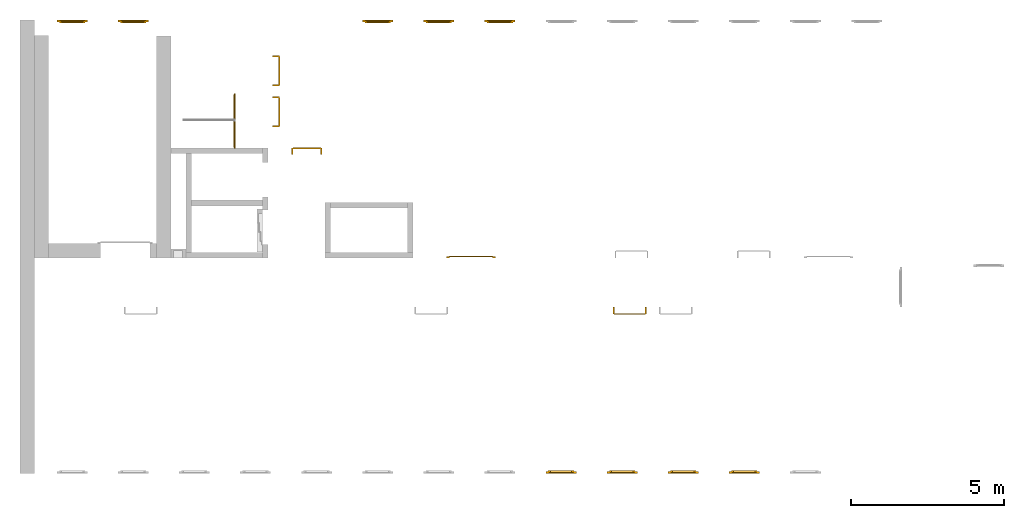
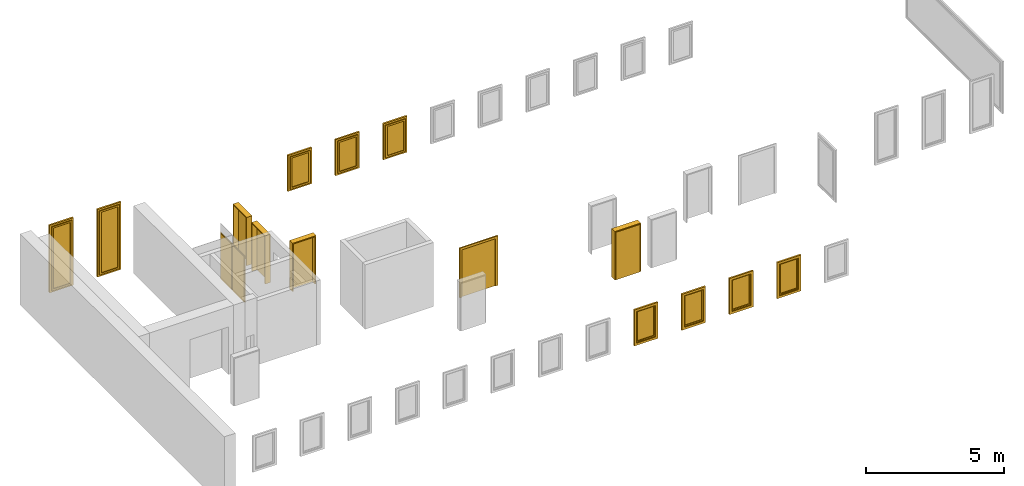
# One storey, part 3 of 5: 9 windows, 7 doors.
"""IFC4 building model written with IfcOpenShell, lengths in metres."""

from ifc_helpers import new_model, entity, si_unit, converted_unit, derived_unit, direction, frame, origin_with_axes, place, context, subcontext, project, spatial, polygons, source, transform, mapped, type_object, element, save


model = new_model("IFC4")

# Units and contexts
model_context = context("Model", 3, precision=1e-05, world=origin_with_axes(), true_north=direction((0.0, 1.0)))
body_context = subcontext(model_context, "Body", "Model", "MODEL_VIEW")
ifc_project = project(units=[si_unit("LENGTHUNIT", "METRE"), si_unit("AREAUNIT", "SQUARE_METRE"), si_unit("VOLUMEUNIT", "CUBIC_METRE"), converted_unit("PLANEANGLEUNIT", "DEGREE", entity("IfcPlaneAngleMeasure", 0.0174532925199433), si_unit("PLANEANGLEUNIT", "RADIAN"), dimensions=[0, 0, 0, 0, 0, 0, 0]), converted_unit("TIMEUNIT", "Year", entity("IfcTimeMeasure", 31557600.0), si_unit("TIMEUNIT", "SECOND"), dimensions=[0, 0, 1, 0, 0, 0, 0]), si_unit("MASSUNIT", "GRAM", prefix="KILO"), si_unit("THERMODYNAMICTEMPERATUREUNIT", "DEGREE_CELSIUS"), si_unit("LUMINOUSINTENSITYUNIT", "LUMEN"), si_unit("ENERGYUNIT", "JOULE", prefix="MEGA"), derived_unit("THERMALCONDUCTANCEUNIT", [(si_unit("POWERUNIT", "WATT"), 1), (si_unit("LENGTHUNIT", "METRE"), -1), (si_unit("THERMODYNAMICTEMPERATUREUNIT", "KELVIN"), -1)]), derived_unit("SPECIFICHEATCAPACITYUNIT", [(si_unit("ENERGYUNIT", "JOULE"), 1), (si_unit("MASSUNIT", "GRAM", prefix="KILO"), -1), (si_unit("THERMODYNAMICTEMPERATUREUNIT", "KELVIN"), -1)]), derived_unit("MASSDENSITYUNIT", [(si_unit("MASSUNIT", "GRAM", prefix="KILO"), 1), (si_unit("VOLUMEUNIT", "CUBIC_METRE"), -1)])], contexts=[model_context])

# Site, building, storey
site_placement = place(None, origin_with_axes())
site = spatial("IfcSite", under=ifc_project, at=site_placement, CompositionType="ELEMENT")
building_placement = place(None, origin_with_axes())
building = spatial("IfcBuilding", under=site, at=building_placement, CompositionType="ELEMENT")
storey_placement = place(None, frame((0.0, 0.0, 7.5), z_axis=(0.0, 0.0, 1.0), x_axis=(1.0, 0.0, 0.0)))
storey = spatial("IfcBuildingStorey", under=building, at=storey_placement, Name="2 OG", CompositionType="ELEMENT", Elevation=7.5)

# Windows
window_type = type_object("IfcWindowType", Name="1-27", PartitioningType="SINGLE_PANEL", PredefinedType="WINDOW")
shared_shape_1 = source(origin_with_axes(), body_context, "Body", "Tessellation", [
    polygons([(-0.5, -0.07, 0.0), (-0.5, 0.0, 0.0), (-0.4, 0.0, 0.1), (-0.4, -0.07, 0.1), (-0.5, -0.07, 1.6), (-0.5, 0.0, 1.6), (-0.4, 0.0, 1.5), (-0.4, -0.07, 1.5)], [[[1, 2, 3, 4]], [[5, 6, 2, 1]], [[2, 6, 7, 3]], [[4, 3, 7, 8]], [[1, 4, 8, 5]], [[8, 7, 6, 5]]], closed=True),
    polygons([(0.5, -0.07, 0.0), (0.5, 0.0, 0.0), (0.5, 0.0, 1.6), (0.5, -0.07, 1.6), (0.4, -0.07, 0.1), (0.4, 0.0, 0.1), (0.4, 0.0, 1.5), (0.4, -0.07, 1.5)], [[[1, 2, 3, 4]], [[5, 6, 2, 1]], [[2, 6, 7, 3]], [[4, 3, 7, 8]], [[1, 4, 8, 5]], [[8, 7, 6, 5]]], closed=True),
    polygons([(-0.5, -0.07, 0.0), (-0.5, 0.0, 0.0), (0.5, 0.0, 0.0), (0.5, -0.07, 0.0), (-0.4, -0.07, 0.1), (-0.4, 0.0, 0.1), (0.0, 0.0, 0.1), (0.4, 0.0, 0.1), (0.4, -0.07, 0.1), (0.0, -0.07, 0.1)], [[[1, 2, 3, 4]], [[5, 6, 2, 1]], [[2, 6, 7, 8, 3]], [[4, 3, 8, 9]], [[1, 4, 9, 10, 5]], [[10, 7, 6, 5]], [[9, 8, 7, 10]]], closed=True),
    polygons([(-0.5, -0.07, 1.6), (-0.5, 0.0, 1.6), (-0.4, 0.0, 1.5), (-0.4, -0.07, 1.5), (0.5, -0.07, 1.6), (0.5, 0.0, 1.6), (0.4, 0.0, 1.5), (0.0, 0.0, 1.5), (0.0, -0.07, 1.5), (0.4, -0.07, 1.5)], [[[1, 2, 3, 4]], [[5, 6, 2, 1]], [[2, 6, 7, 8, 3]], [[4, 3, 8, 9]], [[1, 4, 9, 10, 5]], [[10, 7, 6, 5]], [[9, 8, 7, 10]]], closed=True),
    polygons([(-0.42, 0.0, 0.08), (-0.42, 0.03, 0.08), (-0.35, 0.03, 0.15), (-0.35, 0.0, 0.15), (-0.42, 0.0, 1.52), (-0.42, 0.03, 1.52), (-0.35, 0.03, 1.45), (-0.35, 0.0, 1.45)], [[[1, 2, 3, 4]], [[5, 6, 2, 1]], [[2, 6, 7, 3]], [[4, 3, 7, 8]], [[1, 4, 8, 5]], [[8, 7, 6, 5]]], closed=True),
    polygons([(0.42, 0.0, 0.08), (0.35, 0.0, 0.15), (0.35, 0.03, 0.15), (0.42, 0.03, 0.08), (0.42, 0.0, 1.52), (0.35, 0.0, 1.45), (0.35, 0.03, 1.45), (0.42, 0.03, 1.52)], [[[1, 2, 3, 4]], [[1, 5, 6, 2]], [[2, 6, 7, 3]], [[4, 3, 7, 8]], [[5, 1, 4, 8]], [[6, 5, 8, 7]]], closed=True),
    polygons([(-0.42, 0.0, 0.08), (-0.42, 0.03, 0.08), (0.42, 0.03, 0.08), (0.42, 0.0, 0.08), (-0.35, 0.0, 0.15), (-0.35, 0.03, 0.15), (0.35, 0.03, 0.15), (0.35, 0.0, 0.15)], [[[1, 2, 3, 4]], [[5, 6, 2, 1]], [[2, 6, 7, 3]], [[4, 3, 7, 8]], [[1, 4, 8, 5]], [[8, 7, 6, 5]]], closed=True),
    polygons([(-0.42, 0.0, 1.52), (0.42, 0.0, 1.52), (0.42, 0.03, 1.52), (-0.42, 0.03, 1.52), (-0.35, 0.0, 1.45), (0.35, 0.0, 1.45), (0.35, 0.03, 1.45), (-0.35, 0.03, 1.45)], [[[1, 2, 3, 4]], [[1, 5, 6, 2]], [[2, 6, 7, 3]], [[4, 3, 7, 8]], [[5, 1, 4, 8]], [[6, 5, 8, 7]]], closed=True),
    polygons([(-0.4, -0.03, 0.1), (-0.4, 0.0, 0.1), (-0.35, 0.0, 0.15), (-0.35, -0.03, 0.15), (-0.4, -0.03, 1.5), (-0.4, 0.0, 1.5), (-0.35, 0.0, 1.45), (-0.35, -0.03, 1.45)], [[[1, 2, 3, 4]], [[5, 6, 2, 1]], [[2, 6, 7, 3]], [[4, 3, 7, 8]], [[1, 4, 8, 5]], [[8, 7, 6, 5]]], closed=True),
    polygons([(0.4, -0.03, 0.1), (0.35, -0.03, 0.15), (0.35, 0.0, 0.15), (0.4, 0.0, 0.1), (0.4, -0.03, 1.5), (0.35, -0.03, 1.45), (0.35, 0.0, 1.45), (0.4, 0.0, 1.5)], [[[1, 2, 3, 4]], [[1, 5, 6, 2]], [[2, 6, 7, 3]], [[4, 3, 7, 8]], [[5, 1, 4, 8]], [[6, 5, 8, 7]]], closed=True),
    polygons([(-0.4, -0.03, 0.1), (-0.4, 0.0, 0.1), (0.4, 0.0, 0.1), (0.4, -0.03, 0.1), (-0.35, -0.03, 0.15), (-0.35, 0.0, 0.15), (0.35, 0.0, 0.15), (0.35, -0.03, 0.15)], [[[1, 2, 3, 4]], [[5, 6, 2, 1]], [[2, 6, 7, 3]], [[4, 3, 7, 8]], [[1, 4, 8, 5]], [[8, 7, 6, 5]]], closed=True),
    polygons([(-0.4, -0.03, 1.5), (0.4, -0.03, 1.5), (0.4, 0.0, 1.5), (-0.4, 0.0, 1.5), (-0.35, -0.03, 1.45), (0.35, -0.03, 1.45), (0.35, 0.0, 1.45), (-0.35, 0.0, 1.45)], [[[1, 2, 3, 4]], [[1, 5, 6, 2]], [[2, 6, 7, 3]], [[4, 3, 7, 8]], [[5, 1, 4, 8]], [[6, 5, 8, 7]]], closed=True),
    polygons([(-0.35, -0.00500000000000001, 0.15), (-0.35, 0.00499999999999999, 0.15), (0.35, 0.00499999999999999, 0.15), (0.35, -0.00500000000000001, 0.15), (-0.35, -0.00500000000000001, 1.45), (-0.35, 0.00499999999999999, 1.45), (0.35, 0.00499999999999999, 1.45), (0.35, -0.00500000000000001, 1.45)], [[[1, 2, 3, 4]], [[5, 6, 2, 1]], [[2, 6, 7, 3]], [[4, 3, 7, 8]], [[1, 4, 8, 5]], [[8, 7, 6, 5]]], closed=True),
])
window_1_placement = place(None, frame((46.723, 0.0, 8.5), z_axis=(0.0, 0.0, 1.0), x_axis=(1.0, 0.0, 0.0)))
element("IfcWindow", 1, at=window_1_placement, inside=storey, type_object=window_type, Name="Fenster-001", OverallHeight=1.6, OverallWidth=1.0, context=body_context, shape_type="MappedRepresentation", body=[
    mapped(shared_shape_1, transform((0.5, 0.0700000000000007, 0.0))),
])
window_2_placement = place(None, frame((42.723, 0.0, 8.5), z_axis=(0.0, 0.0, 1.0), x_axis=(1.0, 0.0, 0.0)))
element("IfcWindow", 2, at=window_2_placement, inside=storey, type_object=window_type, Name="Fenster-001", OverallHeight=1.6, OverallWidth=1.0, context=body_context, shape_type="MappedRepresentation", body=[
    mapped(shared_shape_1, transform((0.5, 0.0700000000000013, 0.0))),
])
window_3_placement = place(None, frame((40.723, 0.0, 8.5), z_axis=(0.0, 0.0, 1.0), x_axis=(1.0, 0.0, 0.0)))
element("IfcWindow", 3, at=window_3_placement, inside=storey, type_object=window_type, Name="Fenster-001", OverallHeight=1.6, OverallWidth=1.0, context=body_context, shape_type="MappedRepresentation", body=[
    mapped(shared_shape_1, transform((0.5, 0.0700000000000015, 0.0))),
])
window_4_placement = place(None, frame((44.723, 0.0, 8.5), z_axis=(0.0, 0.0, 1.0), x_axis=(1.0, 0.0, 0.0)))
element("IfcWindow", 4, at=window_4_placement, inside=storey, type_object=window_type, Name="Fenster-001", OverallHeight=1.6, OverallWidth=1.0, context=body_context, shape_type="MappedRepresentation", body=[
    mapped(shared_shape_1, transform((0.5, 0.0700000000000011, 0.0))),
])
shared_shape_2 = source(origin_with_axes(), body_context, "Body", "Tessellation", [
    polygons([(0.5, -0.07, 0.0), (0.4, -0.07, 0.1), (0.4, 0.0, 0.1), (0.5, 0.0, 0.0), (0.5, -0.07, 1.6), (0.4, -0.07, 1.5), (0.4, 0.0, 1.5), (0.5, 0.0, 1.6)], [[[1, 2, 3, 4]], [[1, 5, 6, 2]], [[2, 6, 7, 3]], [[4, 3, 7, 8]], [[5, 1, 4, 8]], [[6, 5, 8, 7]]], closed=True),
    polygons([(-0.5, -0.07, 0.0), (-0.5, -0.07, 1.6), (-0.5, 0.0, 1.6), (-0.5, 0.0, 0.0), (-0.4, -0.07, 0.1), (-0.4, -0.07, 1.5), (-0.4, 0.0, 1.5), (-0.4, 0.0, 0.1)], [[[1, 2, 3, 4]], [[1, 5, 6, 2]], [[2, 6, 7, 3]], [[4, 3, 7, 8]], [[5, 1, 4, 8]], [[6, 5, 8, 7]]], closed=True),
    polygons([(0.5, -0.07, 0.0), (-0.5, -0.07, 0.0), (-0.5, 0.0, 0.0), (0.5, 0.0, 0.0), (0.4, -0.07, 0.1), (0.0, -0.07, 0.1), (-0.4, -0.07, 0.1), (-0.4, 0.0, 0.1), (0.0, 0.0, 0.1), (0.4, 0.0, 0.1)], [[[1, 2, 3, 4]], [[1, 5, 6, 7, 2]], [[2, 7, 8, 3]], [[4, 3, 8, 9, 10]], [[5, 1, 4, 10]], [[6, 5, 10, 9]], [[7, 6, 9, 8]]], closed=True),
    polygons([(0.5, -0.07, 1.6), (0.4, -0.07, 1.5), (0.4, 0.0, 1.5), (0.5, 0.0, 1.6), (-0.5, -0.07, 1.6), (-0.4, -0.07, 1.5), (0.0, -0.07, 1.5), (0.0, 0.0, 1.5), (-0.4, 0.0, 1.5), (-0.5, 0.0, 1.6)], [[[1, 2, 3, 4]], [[1, 5, 6, 7, 2]], [[2, 7, 8, 3]], [[4, 3, 8, 9, 10]], [[5, 1, 4, 10]], [[6, 5, 10, 9]], [[7, 6, 9, 8]]], closed=True),
    polygons([(0.42, 0.0, 0.08), (0.35, 0.0, 0.15), (0.35, 0.03, 0.15), (0.42, 0.03, 0.08), (0.42, 0.0, 1.52), (0.35, 0.0, 1.45), (0.35, 0.03, 1.45), (0.42, 0.03, 1.52)], [[[1, 2, 3, 4]], [[1, 5, 6, 2]], [[2, 6, 7, 3]], [[4, 3, 7, 8]], [[5, 1, 4, 8]], [[6, 5, 8, 7]]], closed=True),
    polygons([(-0.42, 0.0, 0.08), (-0.42, 0.03, 0.08), (-0.35, 0.03, 0.15), (-0.35, 0.0, 0.15), (-0.42, 0.0, 1.52), (-0.42, 0.03, 1.52), (-0.35, 0.03, 1.45), (-0.35, 0.0, 1.45)], [[[1, 2, 3, 4]], [[5, 6, 2, 1]], [[2, 6, 7, 3]], [[4, 3, 7, 8]], [[1, 4, 8, 5]], [[8, 7, 6, 5]]], closed=True),
    polygons([(0.42, 0.0, 0.08), (-0.42, 0.0, 0.08), (-0.42, 0.03, 0.08), (0.42, 0.03, 0.08), (0.35, 0.0, 0.15), (-0.35, 0.0, 0.15), (-0.35, 0.03, 0.15), (0.35, 0.03, 0.15)], [[[1, 2, 3, 4]], [[1, 5, 6, 2]], [[2, 6, 7, 3]], [[4, 3, 7, 8]], [[5, 1, 4, 8]], [[6, 5, 8, 7]]], closed=True),
    polygons([(0.42, 0.0, 1.52), (0.42, 0.03, 1.52), (-0.42, 0.03, 1.52), (-0.42, 0.0, 1.52), (0.35, 0.0, 1.45), (0.35, 0.03, 1.45), (-0.35, 0.03, 1.45), (-0.35, 0.0, 1.45)], [[[1, 2, 3, 4]], [[5, 6, 2, 1]], [[2, 6, 7, 3]], [[4, 3, 7, 8]], [[1, 4, 8, 5]], [[8, 7, 6, 5]]], closed=True),
    polygons([(0.4, -0.03, 0.1), (0.35, -0.03, 0.15), (0.35, 0.0, 0.15), (0.4, 0.0, 0.1), (0.4, -0.03, 1.5), (0.35, -0.03, 1.45), (0.35, 0.0, 1.45), (0.4, 0.0, 1.5)], [[[1, 2, 3, 4]], [[1, 5, 6, 2]], [[2, 6, 7, 3]], [[4, 3, 7, 8]], [[5, 1, 4, 8]], [[6, 5, 8, 7]]], closed=True),
    polygons([(-0.4, -0.03, 0.1), (-0.4, 0.0, 0.1), (-0.35, 0.0, 0.15), (-0.35, -0.03, 0.15), (-0.4, -0.03, 1.5), (-0.4, 0.0, 1.5), (-0.35, 0.0, 1.45), (-0.35, -0.03, 1.45)], [[[1, 2, 3, 4]], [[5, 6, 2, 1]], [[2, 6, 7, 3]], [[4, 3, 7, 8]], [[1, 4, 8, 5]], [[8, 7, 6, 5]]], closed=True),
    polygons([(0.4, -0.03, 0.1), (-0.4, -0.03, 0.1), (-0.4, 0.0, 0.1), (0.4, 0.0, 0.1), (0.35, -0.03, 0.15), (-0.35, -0.03, 0.15), (-0.35, 0.0, 0.15), (0.35, 0.0, 0.15)], [[[1, 2, 3, 4]], [[1, 5, 6, 2]], [[2, 6, 7, 3]], [[4, 3, 7, 8]], [[5, 1, 4, 8]], [[6, 5, 8, 7]]], closed=True),
    polygons([(0.4, -0.03, 1.5), (0.4, 0.0, 1.5), (-0.4, 0.0, 1.5), (-0.4, -0.03, 1.5), (0.35, -0.03, 1.45), (0.35, 0.0, 1.45), (-0.35, 0.0, 1.45), (-0.35, -0.03, 1.45)], [[[1, 2, 3, 4]], [[5, 6, 2, 1]], [[2, 6, 7, 3]], [[4, 3, 7, 8]], [[1, 4, 8, 5]], [[8, 7, 6, 5]]], closed=True),
    polygons([(0.35, -0.00500000000000001, 0.15), (-0.35, -0.00500000000000001, 0.15), (-0.35, 0.00499999999999999, 0.15), (0.35, 0.00499999999999999, 0.15), (0.35, -0.00500000000000001, 1.45), (-0.35, -0.00500000000000001, 1.45), (-0.35, 0.00499999999999999, 1.45), (0.35, 0.00499999999999999, 1.45)], [[[1, 2, 3, 4]], [[1, 5, 6, 2]], [[2, 6, 7, 3]], [[4, 3, 7, 8]], [[5, 1, 4, 8]], [[6, 5, 8, 7]]], closed=True),
])
for number, where, z_axis, x_axis, name in (
    (5, (35.723, 14.8459998909351, 8.5), (0.0, 0.0, 1.0), (-1.0, 0.0, 0.0), "Fenster-001"),
    (6, (37.723, 14.8459998909351, 8.5), (0.0, 0.0, 1.0), (-1.0, 0.0, 0.0), "Fenster-001"),
):
    element("IfcWindow", number, at=place(None, frame(where, z_axis=z_axis, x_axis=x_axis)), inside=storey, type_object=window_type, Name=name, OverallHeight=1.6, OverallWidth=1.0, context=body_context, shape_type="MappedRepresentation", body=[
        mapped(shared_shape_2, transform((0.5, 0.0699999999999967, 0.0))),
    ])
window_5_placement = place(None, frame((39.723, 14.8459998909351, 8.5), z_axis=(0.0, 0.0, 1.0), x_axis=(-1.0, 0.0, 0.0)))
element("IfcWindow", 7, at=window_5_placement, inside=storey, type_object=window_type, Name="Fenster-001", OverallHeight=1.6, OverallWidth=1.0, context=body_context, shape_type="MappedRepresentation", body=[
    mapped(shared_shape_2, transform((0.5, 0.0699999999999985, 0.0))),
])

# Space
space_placement = place(None, frame((28.883, 12.4404999136732, 7.5), z_axis=(0.0, 0.0, 1.0), x_axis=(0.0, -1.0, 0.0)))
space = spatial("IfcSpace", under=storey, at=space_placement, CompositionType="ELEMENT", PredefinedType="NOTDEFINED")

# Doors
door_type_1 = type_object("IfcDoorType", Name="27", OperationType="SINGLE_SWING_LEFT", PredefinedType="DOOR")
shared_shape_3 = source(origin_with_axes(), body_context, "Body", "Tessellation", [
    polygons([(-0.445, -0.025, 0.0), (-0.445, -0.025, 2.045), (-0.445, 0.0, 2.045), (-0.445, 0.0, 0.0), (-0.41, -0.025, 0.0), (-0.41, -0.025, 2.01), (-0.0451, -0.025, 2.01), (-0.0101, -0.025, 2.01), (0.41, -0.025, 2.01), (0.41, -0.025, 0.0), (0.445, -0.025, 0.0), (0.445, -0.025, 2.045), (0.445, 0.0, 2.045), (0.445, 0.0, 0.0), (0.41, 0.0, 0.0), (0.41, 0.0, 2.01), (-0.0101, 0.0, 2.01), (-0.0451, 0.0, 2.01), (-0.41, 0.0, 2.01), (-0.41, 0.0, 0.0)], [[[1, 2, 3, 4]], [[1, 5, 6, 7, 8, 9, 10, 11, 12, 2]], [[2, 12, 13, 3]], [[4, 3, 13, 14, 15, 16, 17, 18, 19, 20]], [[5, 1, 4, 20]], [[6, 5, 20, 19]], [[7, 6, 19, 18]], [[8, 7, 18, 17]], [[9, 8, 17, 16]], [[10, 9, 16, 15]], [[11, 10, 15, 14]], [[12, 11, 14, 13]]], closed=True),
    polygons([(-0.41, 0.015, 0.0), (-0.41, 0.015, 2.01), (0.41, 0.015, 2.01), (0.41, 0.015, 0.0), (-0.41, -0.025, 0.0), (-0.41, -0.025, 2.01), (0.41, -0.025, 2.01), (0.41, -0.025, 0.0)], [[[1, 2, 3, 4]], [[1, 5, 6, 2]], [[2, 6, 7, 3]], [[3, 7, 8, 4]], [[4, 8, 5, 1]], [[8, 7, 6, 5]]], closed=True),
])
door_1_placement = place(None, frame((30.553, 10.6999999454676, 7.55), z_axis=(0.0, 0.0, 1.0), x_axis=(0.0, 1.0, 0.0)))
element("IfcDoor", 8, at=door_1_placement, inside=space, type_object=door_type_1, OverallHeight=2.095, OverallWidth=0.89, context=body_context, shape_type="MappedRepresentation", body=[
    mapped(shared_shape_3, transform((0.4, 0.0199999999999996, 0.0))),
])
door_type_2 = type_object("IfcDoorType", Name="2-Fl 27", OperationType="DOUBLE_DOOR_SINGLE_SWING", PredefinedType="DOOR")
shared_shape_4 = source(origin_with_axes(), body_context, "Body", "Tessellation", [
    polygons([(0.8, -0.05, 0.0), (0.8, -0.02, 0.0), (0.8, -0.02, 2.2), (0.8, -0.05, 2.2), (0.7, -0.05, 0.0), (0.7, -0.02, 0.0), (0.7, -0.02, 2.1), (0.1251, -0.02, 2.1), (0.0001, -0.02, 2.1), (-0.7, -0.02, 2.1), (-0.7, -0.02, 0.0), (-0.8, -0.02, 0.0), (-0.8, -0.02, 2.2), (-0.8, -0.05, 2.2), (-0.8, -0.05, 0.0), (-0.7, -0.05, 0.0), (-0.7, -0.05, 2.1), (0.0001, -0.05, 2.1), (0.1251, -0.05, 2.1), (0.7, -0.05, 2.1)], [[[1, 2, 3, 4]], [[5, 6, 2, 1]], [[2, 6, 7, 8, 9, 10, 11, 12, 13, 3]], [[4, 3, 13, 14]], [[1, 4, 14, 15, 16, 17, 18, 19, 20, 5]], [[20, 7, 6, 5]], [[19, 8, 7, 20]], [[18, 9, 8, 19]], [[17, 10, 9, 18]], [[16, 11, 10, 17]], [[15, 12, 11, 16]], [[14, 13, 12, 15]]], closed=True),
    polygons([(0.8, -0.02, 0.0), (0.8, 0.0, 0.0), (0.8, 0.0, 2.2), (0.8, -0.02, 2.2), (0.725, -0.02, 0.0), (0.725, 0.0, 0.0), (0.725, 0.0, 2.125), (0.1001, 0.0, 2.125), (0.0251, 0.0, 2.125), (-0.725, 0.0, 2.125), (-0.725, 0.0, 0.0), (-0.8, 0.0, 0.0), (-0.8, 0.0, 2.2), (-0.8, -0.02, 2.2), (-0.8, -0.02, 0.0), (-0.725, -0.02, 0.0), (-0.725, -0.02, 2.125), (0.0251, -0.02, 2.125), (0.1001, -0.02, 2.125), (0.725, -0.02, 2.125)], [[[1, 2, 3, 4]], [[5, 6, 2, 1]], [[2, 6, 7, 8, 9, 10, 11, 12, 13, 3]], [[4, 3, 13, 14]], [[1, 4, 14, 15, 16, 17, 18, 19, 20, 5]], [[20, 7, 6, 5]], [[19, 8, 7, 20]], [[18, 9, 8, 19]], [[17, 10, 9, 18]], [[16, 11, 10, 17]], [[15, 12, 11, 16]], [[14, 13, 12, 15]]], closed=True),
    polygons([(0.725, 0.02, 0.0), (0.000499999999999945, 0.02, 0.0), (0.000499999999999945, 0.02, 2.125), (0.725, 0.02, 2.125), (0.725, -0.02, 0.0), (0.000499999999999945, -0.02, 0.0), (0.000499999999999945, -0.02, 2.125), (0.725, -0.02, 2.125)], [[[1, 2, 3, 4]], [[2, 1, 5, 6]], [[3, 2, 6, 7]], [[4, 3, 7, 8]], [[1, 4, 8, 5]], [[6, 5, 8, 7]]], closed=True),
    polygons([(-0.725, 0.02, 0.0), (-0.725, 0.02, 2.125), (-0.000499999999999945, 0.02, 2.125), (-0.000499999999999945, 0.02, 0.0), (-0.725, -0.02, 0.0), (-0.725, -0.02, 2.125), (-0.000499999999999945, -0.02, 2.125), (-0.000499999999999945, -0.02, 0.0)], [[[1, 2, 3, 4]], [[1, 5, 6, 2]], [[2, 6, 7, 3]], [[3, 7, 8, 4]], [[4, 8, 5, 1]], [[8, 7, 6, 5]]], closed=True),
])
door_2_placement = place(None, frame((37.577, 7.05499994546756, 7.5), z_axis=(0.0, 0.0, 1.0), x_axis=(1.0, 0.0, 0.0)))
element("IfcDoor", 9, at=door_2_placement, inside=storey, type_object=door_type_2, OverallHeight=2.2, OverallWidth=1.6, context=body_context, shape_type="MappedRepresentation", body=[
    mapped(shared_shape_4, transform((0.700000000000003, 0.0499999999999998, 0.0))),
])
shared_shape_5 = source(origin_with_axes(), body_context, "Body", "Tessellation", [
    polygons([(-0.495, -0.218, 0.0), (-0.495, -0.218, 2.145), (-0.495, -0.025, 2.145), (-0.495, -0.025, 0.0), (-0.45, -0.218, 0.0), (-0.45, -0.218, 2.1), (-0.0551, -0.218, 2.1), (-0.0001, -0.218, 2.1), (0.45, -0.218, 2.1), (0.45, -0.218, 0.0), (0.495, -0.218, 0.0), (0.495, -0.218, 2.145), (0.495, -0.025, 2.145), (0.495, -0.025, 0.0), (0.45, -0.025, 0.0), (0.45, -0.025, 2.1), (-0.0001, -0.025, 2.1), (-0.0551, -0.025, 2.1), (-0.45, -0.025, 2.1), (-0.45, -0.025, 0.0)], [[[1, 2, 3, 4]], [[1, 5, 6, 7, 8, 9, 10, 11, 12, 2]], [[2, 12, 13, 3]], [[4, 3, 13, 14, 15, 16, 17, 18, 19, 20]], [[5, 1, 4, 20]], [[6, 5, 20, 19]], [[7, 6, 19, 18]], [[8, 7, 18, 17]], [[9, 8, 17, 16]], [[10, 9, 16, 15]], [[11, 10, 15, 14]], [[12, 11, 14, 13]]], closed=True),
    polygons([(-0.495, -0.025, 0.0), (-0.495, -0.025, 2.145), (-0.495, 0.0, 2.145), (-0.495, 0.0, 0.0), (-0.46, -0.025, 0.0), (-0.46, -0.025, 2.11), (-0.0451, -0.025, 2.11), (-0.0101, -0.025, 2.11), (0.46, -0.025, 2.11), (0.46, -0.025, 0.0), (0.495, -0.025, 0.0), (0.495, -0.025, 2.145), (0.495, 0.0, 2.145), (0.495, 0.0, 0.0), (0.46, 0.0, 0.0), (0.46, 0.0, 2.11), (-0.0101, 0.0, 2.11), (-0.0451, 0.0, 2.11), (-0.46, 0.0, 2.11), (-0.46, 0.0, 0.0)], [[[1, 2, 3, 4]], [[1, 5, 6, 7, 8, 9, 10, 11, 12, 2]], [[2, 12, 13, 3]], [[4, 3, 13, 14, 15, 16, 17, 18, 19, 20]], [[5, 1, 4, 20]], [[6, 5, 20, 19]], [[7, 6, 19, 18]], [[8, 7, 18, 17]], [[9, 8, 17, 16]], [[10, 9, 16, 15]], [[11, 10, 15, 14]], [[12, 11, 14, 13]]], closed=True),
    polygons([(-0.46, 0.015, 0.0), (-0.46, 0.015, 2.11), (0.46, 0.015, 2.11), (0.46, 0.015, 0.0), (-0.46, -0.025, 0.0), (-0.46, -0.025, 2.11), (0.46, -0.025, 2.11), (0.46, -0.025, 0.0)], [[[1, 2, 3, 4]], [[1, 5, 6, 2]], [[2, 6, 7, 3]], [[3, 7, 8, 4]], [[4, 8, 5, 1]], [[8, 7, 6, 5]]], closed=True),
])
for number, where, z_axis, x_axis in (
    (10, (32.005, 13.6354999136732, 7.5), (0.0, 0.0, 1.0), (0.0, -1.0, 0.0)),
    (11, (32.005, 12.2904999136732, 7.5), (0.0, 0.0, 1.0), (0.0, -1.0, 0.0)),
):
    element("IfcDoor", number, at=place(None, frame(where, z_axis=z_axis, x_axis=x_axis)), inside=storey, type_object=door_type_1, OverallHeight=2.145, OverallWidth=0.99, context=body_context, shape_type="MappedRepresentation", body=[
        mapped(shared_shape_5, transform((0.449999999999999, 0.0, 0.0))),
    ])
door_type_3 = type_object("IfcDoorType", Name="27", OperationType="SINGLE_SWING_RIGHT", PredefinedType="DOOR")
shared_shape_6 = source(origin_with_axes(), body_context, "Body", "Tessellation", [
    polygons([(0.445, -0.025, 0.0), (0.445, 0.0, 0.0), (0.445, 0.0, 2.045), (0.445, -0.025, 2.045), (0.41, -0.025, 0.0), (0.41, 0.0, 0.0), (0.41, 0.0, 2.01), (0.0451, 0.0, 2.01), (0.0101, 0.0, 2.01), (-0.41, 0.0, 2.01), (-0.41, 0.0, 0.0), (-0.445, 0.0, 0.0), (-0.445, 0.0, 2.045), (-0.445, -0.025, 2.045), (-0.445, -0.025, 0.0), (-0.41, -0.025, 0.0), (-0.41, -0.025, 2.01), (0.0101, -0.025, 2.01), (0.0451, -0.025, 2.01), (0.41, -0.025, 2.01)], [[[1, 2, 3, 4]], [[5, 6, 2, 1]], [[2, 6, 7, 8, 9, 10, 11, 12, 13, 3]], [[4, 3, 13, 14]], [[1, 4, 14, 15, 16, 17, 18, 19, 20, 5]], [[20, 7, 6, 5]], [[19, 8, 7, 20]], [[18, 9, 8, 19]], [[17, 10, 9, 18]], [[16, 11, 10, 17]], [[15, 12, 11, 16]], [[14, 13, 12, 15]]], closed=True),
    polygons([(0.41, 0.015, 0.0), (-0.41, 0.015, 0.0), (-0.41, 0.015, 2.01), (0.41, 0.015, 2.01), (0.41, -0.025, 0.0), (-0.41, -0.025, 0.0), (-0.41, -0.025, 2.01), (0.41, -0.025, 2.01)], [[[1, 2, 3, 4]], [[2, 1, 5, 6]], [[3, 2, 6, 7]], [[4, 3, 7, 8]], [[1, 4, 8, 5]], [[6, 5, 8, 7]]], closed=True),
])
door_3_placement = place(None, frame((30.553, 11.5954999136732, 7.55), z_axis=(0.0, 0.0, 1.0), x_axis=(0.0, 1.0, 0.0)))
element("IfcDoor", 12, at=door_3_placement, inside=space, type_object=door_type_3, OverallHeight=2.095, OverallWidth=0.89, context=body_context, shape_type="MappedRepresentation", body=[
    mapped(shared_shape_6, transform((0.4, 0.0199999999999996, 0.0))),
])
shared_shape_7 = source(origin_with_axes(), body_context, "Body", "Tessellation", [
    polygons([(0.495, -0.218, 0.0), (0.495, -0.025, 0.0), (0.495, -0.025, 2.145), (0.495, -0.218, 2.145), (0.45, -0.218, 0.0), (0.45, -0.025, 0.0), (0.45, -0.025, 2.1), (0.0551, -0.025, 2.1), (0.0001, -0.025, 2.1), (-0.45, -0.025, 2.1), (-0.45, -0.025, 0.0), (-0.495, -0.025, 0.0), (-0.495, -0.025, 2.145), (-0.495, -0.218, 2.145), (-0.495, -0.218, 0.0), (-0.45, -0.218, 0.0), (-0.45, -0.218, 2.1), (0.0001, -0.218, 2.1), (0.0551, -0.218, 2.1), (0.45, -0.218, 2.1)], [[[1, 2, 3, 4]], [[5, 6, 2, 1]], [[2, 6, 7, 8, 9, 10, 11, 12, 13, 3]], [[4, 3, 13, 14]], [[1, 4, 14, 15, 16, 17, 18, 19, 20, 5]], [[20, 7, 6, 5]], [[19, 8, 7, 20]], [[18, 9, 8, 19]], [[17, 10, 9, 18]], [[16, 11, 10, 17]], [[15, 12, 11, 16]], [[14, 13, 12, 15]]], closed=True),
    polygons([(0.495, -0.025, 0.0), (0.495, 0.0, 0.0), (0.495, 0.0, 2.145), (0.495, -0.025, 2.145), (0.46, -0.025, 0.0), (0.46, 0.0, 0.0), (0.46, 0.0, 2.11), (0.0451, 0.0, 2.11), (0.0101, 0.0, 2.11), (-0.46, 0.0, 2.11), (-0.46, 0.0, 0.0), (-0.495, 0.0, 0.0), (-0.495, 0.0, 2.145), (-0.495, -0.025, 2.145), (-0.495, -0.025, 0.0), (-0.46, -0.025, 0.0), (-0.46, -0.025, 2.11), (0.0101, -0.025, 2.11), (0.0451, -0.025, 2.11), (0.46, -0.025, 2.11)], [[[1, 2, 3, 4]], [[5, 6, 2, 1]], [[2, 6, 7, 8, 9, 10, 11, 12, 13, 3]], [[4, 3, 13, 14]], [[1, 4, 14, 15, 16, 17, 18, 19, 20, 5]], [[20, 7, 6, 5]], [[19, 8, 7, 20]], [[18, 9, 8, 19]], [[17, 10, 9, 18]], [[16, 11, 10, 17]], [[15, 12, 11, 16]], [[14, 13, 12, 15]]], closed=True),
    polygons([(0.46, 0.015, 0.0), (-0.46, 0.015, 0.0), (-0.46, 0.015, 2.11), (0.46, 0.015, 2.11), (0.46, -0.025, 0.0), (-0.46, -0.025, 0.0), (-0.46, -0.025, 2.11), (0.46, -0.025, 2.11)], [[[1, 2, 3, 4]], [[2, 1, 5, 6]], [[3, 2, 6, 7]], [[4, 3, 7, 8]], [[1, 4, 8, 5]], [[6, 5, 8, 7]]], closed=True),
])
door_4_placement = place(None, frame((32.455, 10.6549999454676, 7.5), z_axis=(0.0, 0.0, 1.0), x_axis=(1.0, 0.0, 0.0)))
element("IfcDoor", 13, at=door_4_placement, inside=storey, type_object=door_type_3, OverallHeight=2.145, OverallWidth=0.99, context=body_context, shape_type="MappedRepresentation", body=[
    mapped(shared_shape_7, transform((0.450000000000003, 0.0, 0.0))),
])
shared_shape_8 = source(origin_with_axes(), body_context, "Body", "Tessellation", [
    polygons([(-0.545, -0.2325, 0.0), (-0.545, -0.2325, 2.145), (-0.545, -0.025, 2.145), (-0.545, -0.025, 0.0), (-0.5, -0.2325, 0.0), (-0.5, -0.2325, 2.1), (-0.0551, -0.2325, 2.1), (-0.0001, -0.2325, 2.1), (0.5, -0.2325, 2.1), (0.5, -0.2325, 0.0), (0.545, -0.2325, 0.0), (0.545, -0.2325, 2.145), (0.545, -0.025, 2.145), (0.545, -0.025, 0.0), (0.5, -0.025, 0.0), (0.5, -0.025, 2.1), (-0.0001, -0.025, 2.1), (-0.0551, -0.025, 2.1), (-0.5, -0.025, 2.1), (-0.5, -0.025, 0.0)], [[[1, 2, 3, 4]], [[1, 5, 6, 7, 8, 9, 10, 11, 12, 2]], [[2, 12, 13, 3]], [[4, 3, 13, 14, 15, 16, 17, 18, 19, 20]], [[5, 1, 4, 20]], [[6, 5, 20, 19]], [[7, 6, 19, 18]], [[8, 7, 18, 17]], [[9, 8, 17, 16]], [[10, 9, 16, 15]], [[11, 10, 15, 14]], [[12, 11, 14, 13]]], closed=True),
    polygons([(-0.545, -0.025, 0.0), (-0.545, -0.025, 2.145), (-0.545, 0.0, 2.145), (-0.545, 0.0, 0.0), (-0.51, -0.025, 0.0), (-0.51, -0.025, 2.11), (-0.0451, -0.025, 2.11), (-0.0101, -0.025, 2.11), (0.51, -0.025, 2.11), (0.51, -0.025, 0.0), (0.545, -0.025, 0.0), (0.545, -0.025, 2.145), (0.545, 0.0, 2.145), (0.545, 0.0, 0.0), (0.51, 0.0, 0.0), (0.51, 0.0, 2.11), (-0.0101, 0.0, 2.11), (-0.0451, 0.0, 2.11), (-0.51, 0.0, 2.11), (-0.51, 0.0, 0.0)], [[[1, 2, 3, 4]], [[1, 5, 6, 7, 8, 9, 10, 11, 12, 2]], [[2, 12, 13, 3]], [[4, 3, 13, 14, 15, 16, 17, 18, 19, 20]], [[5, 1, 4, 20]], [[6, 5, 20, 19]], [[7, 6, 19, 18]], [[8, 7, 18, 17]], [[9, 8, 17, 16]], [[10, 9, 16, 15]], [[11, 10, 15, 14]], [[12, 11, 14, 13]]], closed=True),
    polygons([(-0.51, 0.015, 0.0), (-0.51, 0.015, 2.11), (0.51, 0.015, 2.11), (0.51, 0.015, 0.0), (-0.51, -0.025, 0.0), (-0.51, -0.025, 2.11), (0.51, -0.025, 2.11), (0.51, -0.025, 0.0)], [[[1, 2, 3, 4]], [[1, 5, 6, 2]], [[2, 6, 7, 3]], [[3, 7, 8, 4]], [[4, 8, 5, 1]], [[8, 7, 6, 5]]], closed=True),
])
door_5_placement = place(None, frame((43.969, 5.45499994546755, 7.5), z_axis=(0.0, 0.0, 1.0), x_axis=(-1.0, 0.0, 0.0)))
element("IfcDoor", 14, at=door_5_placement, inside=storey, type_object=door_type_1, OverallHeight=2.145, OverallWidth=1.09, context=body_context, shape_type="MappedRepresentation", body=[
    mapped(shared_shape_8, transform((0.5, 0.2325, 0.0))),
])

# Windows
shared_shape_9 = source(origin_with_axes(), body_context, "Body", "Tessellation", [
    polygons([(0.5, -0.07, 0.0), (0.4, -0.07, 0.1), (0.4, 0.0, 0.1), (0.5, 0.0, 0.0), (0.5, -0.07, 3.0), (0.4, -0.07, 2.9), (0.4, 0.0, 2.9), (0.5, 0.0, 3.0)], [[[1, 2, 3, 4]], [[1, 5, 6, 2]], [[2, 6, 7, 3]], [[4, 3, 7, 8]], [[5, 1, 4, 8]], [[6, 5, 8, 7]]], closed=True),
    polygons([(-0.5, -0.07, 0.0), (-0.5, -0.07, 3.0), (-0.5, 0.0, 3.0), (-0.5, 0.0, 0.0), (-0.4, -0.07, 0.1), (-0.4, -0.07, 2.9), (-0.4, 0.0, 2.9), (-0.4, 0.0, 0.1)], [[[1, 2, 3, 4]], [[1, 5, 6, 2]], [[2, 6, 7, 3]], [[4, 3, 7, 8]], [[5, 1, 4, 8]], [[6, 5, 8, 7]]], closed=True),
    polygons([(0.5, -0.07, 0.0), (-0.5, -0.07, 0.0), (-0.5, 0.0, 0.0), (0.5, 0.0, 0.0), (0.4, -0.07, 0.1), (0.0, -0.07, 0.1), (-0.4, -0.07, 0.1), (-0.4, 0.0, 0.1), (0.0, 0.0, 0.1), (0.4, 0.0, 0.1)], [[[1, 2, 3, 4]], [[1, 5, 6, 7, 2]], [[2, 7, 8, 3]], [[4, 3, 8, 9, 10]], [[5, 1, 4, 10]], [[6, 5, 10, 9]], [[7, 6, 9, 8]]], closed=True),
    polygons([(0.5, -0.07, 3.0), (0.4, -0.07, 2.9), (0.4, 0.0, 2.9), (0.5, 0.0, 3.0), (-0.5, -0.07, 3.0), (-0.4, -0.07, 2.9), (0.0, -0.07, 2.9), (0.0, 0.0, 2.9), (-0.4, 0.0, 2.9), (-0.5, 0.0, 3.0)], [[[1, 2, 3, 4]], [[1, 5, 6, 7, 2]], [[2, 7, 8, 3]], [[4, 3, 8, 9, 10]], [[5, 1, 4, 10]], [[6, 5, 10, 9]], [[7, 6, 9, 8]]], closed=True),
    polygons([(0.42, 0.0, 0.08), (0.35, 0.0, 0.15), (0.35, 0.03, 0.15), (0.42, 0.03, 0.08), (0.42, 0.0, 2.92), (0.35, 0.0, 2.85), (0.35, 0.03, 2.85), (0.42, 0.03, 2.92)], [[[1, 2, 3, 4]], [[1, 5, 6, 2]], [[2, 6, 7, 3]], [[4, 3, 7, 8]], [[5, 1, 4, 8]], [[6, 5, 8, 7]]], closed=True),
    polygons([(-0.42, 0.0, 0.08), (-0.42, 0.03, 0.08), (-0.35, 0.03, 0.15), (-0.35, 0.0, 0.15), (-0.42, 0.0, 2.92), (-0.42, 0.03, 2.92), (-0.35, 0.03, 2.85), (-0.35, 0.0, 2.85)], [[[1, 2, 3, 4]], [[5, 6, 2, 1]], [[2, 6, 7, 3]], [[4, 3, 7, 8]], [[1, 4, 8, 5]], [[8, 7, 6, 5]]], closed=True),
    polygons([(0.42, 0.0, 0.08), (-0.42, 0.0, 0.08), (-0.42, 0.03, 0.08), (0.42, 0.03, 0.08), (0.35, 0.0, 0.15), (-0.35, 0.0, 0.15), (-0.35, 0.03, 0.15), (0.35, 0.03, 0.15)], [[[1, 2, 3, 4]], [[1, 5, 6, 2]], [[2, 6, 7, 3]], [[4, 3, 7, 8]], [[5, 1, 4, 8]], [[6, 5, 8, 7]]], closed=True),
    polygons([(0.42, 0.0, 2.92), (0.42, 0.03, 2.92), (-0.42, 0.03, 2.92), (-0.42, 0.0, 2.92), (0.35, 0.0, 2.85), (0.35, 0.03, 2.85), (-0.35, 0.03, 2.85), (-0.35, 0.0, 2.85)], [[[1, 2, 3, 4]], [[5, 6, 2, 1]], [[2, 6, 7, 3]], [[4, 3, 7, 8]], [[1, 4, 8, 5]], [[8, 7, 6, 5]]], closed=True),
    polygons([(0.4, -0.03, 0.1), (0.35, -0.03, 0.15), (0.35, 0.0, 0.15), (0.4, 0.0, 0.1), (0.4, -0.03, 2.9), (0.35, -0.03, 2.85), (0.35, 0.0, 2.85), (0.4, 0.0, 2.9)], [[[1, 2, 3, 4]], [[1, 5, 6, 2]], [[2, 6, 7, 3]], [[4, 3, 7, 8]], [[5, 1, 4, 8]], [[6, 5, 8, 7]]], closed=True),
    polygons([(-0.4, -0.03, 0.1), (-0.4, 0.0, 0.1), (-0.35, 0.0, 0.15), (-0.35, -0.03, 0.15), (-0.4, -0.03, 2.9), (-0.4, 0.0, 2.9), (-0.35, 0.0, 2.85), (-0.35, -0.03, 2.85)], [[[1, 2, 3, 4]], [[5, 6, 2, 1]], [[2, 6, 7, 3]], [[4, 3, 7, 8]], [[1, 4, 8, 5]], [[8, 7, 6, 5]]], closed=True),
    polygons([(0.4, -0.03, 0.1), (-0.4, -0.03, 0.1), (-0.4, 0.0, 0.1), (0.4, 0.0, 0.1), (0.35, -0.03, 0.15), (-0.35, -0.03, 0.15), (-0.35, 0.0, 0.15), (0.35, 0.0, 0.15)], [[[1, 2, 3, 4]], [[1, 5, 6, 2]], [[2, 6, 7, 3]], [[4, 3, 7, 8]], [[5, 1, 4, 8]], [[6, 5, 8, 7]]], closed=True),
    polygons([(0.4, -0.03, 2.9), (0.4, 0.0, 2.9), (-0.4, 0.0, 2.9), (-0.4, -0.03, 2.9), (0.35, -0.03, 2.85), (0.35, 0.0, 2.85), (-0.35, 0.0, 2.85), (-0.35, -0.03, 2.85)], [[[1, 2, 3, 4]], [[5, 6, 2, 1]], [[2, 6, 7, 3]], [[4, 3, 7, 8]], [[1, 4, 8, 5]], [[8, 7, 6, 5]]], closed=True),
    polygons([(0.35, -0.00500000000000001, 0.15), (-0.35, -0.00500000000000001, 0.15), (-0.35, 0.00499999999999999, 0.15), (0.35, 0.00499999999999999, 0.15), (0.35, -0.00500000000000001, 2.85), (-0.35, -0.00500000000000001, 2.85), (-0.35, 0.00499999999999999, 2.85), (0.35, 0.00499999999999999, 2.85)], [[[1, 2, 3, 4]], [[1, 5, 6, 2]], [[2, 6, 7, 3]], [[4, 3, 7, 8]], [[5, 1, 4, 8]], [[6, 5, 8, 7]]], closed=True),
])
for number, where, z_axis, x_axis, name in (
    (15, (25.723, 14.8459998909351, 7.5), (0.0, 0.0, 1.0), (-1.0, 0.0, 0.0), "Fenster-001"),
    (16, (27.723, 14.8459998909351, 7.5), (0.0, 0.0, 1.0), (-1.0, 0.0, 0.0), "Fenster-001"),
):
    element("IfcWindow", number, at=place(None, frame(where, z_axis=z_axis, x_axis=x_axis)), inside=storey, type_object=window_type, Name=name, OverallHeight=3.0, OverallWidth=1.0, context=body_context, shape_type="MappedRepresentation", body=[
        mapped(shared_shape_9, transform((0.5, 0.0699999999999967, 0.0))),
    ])

save(model, "model.ifc")
